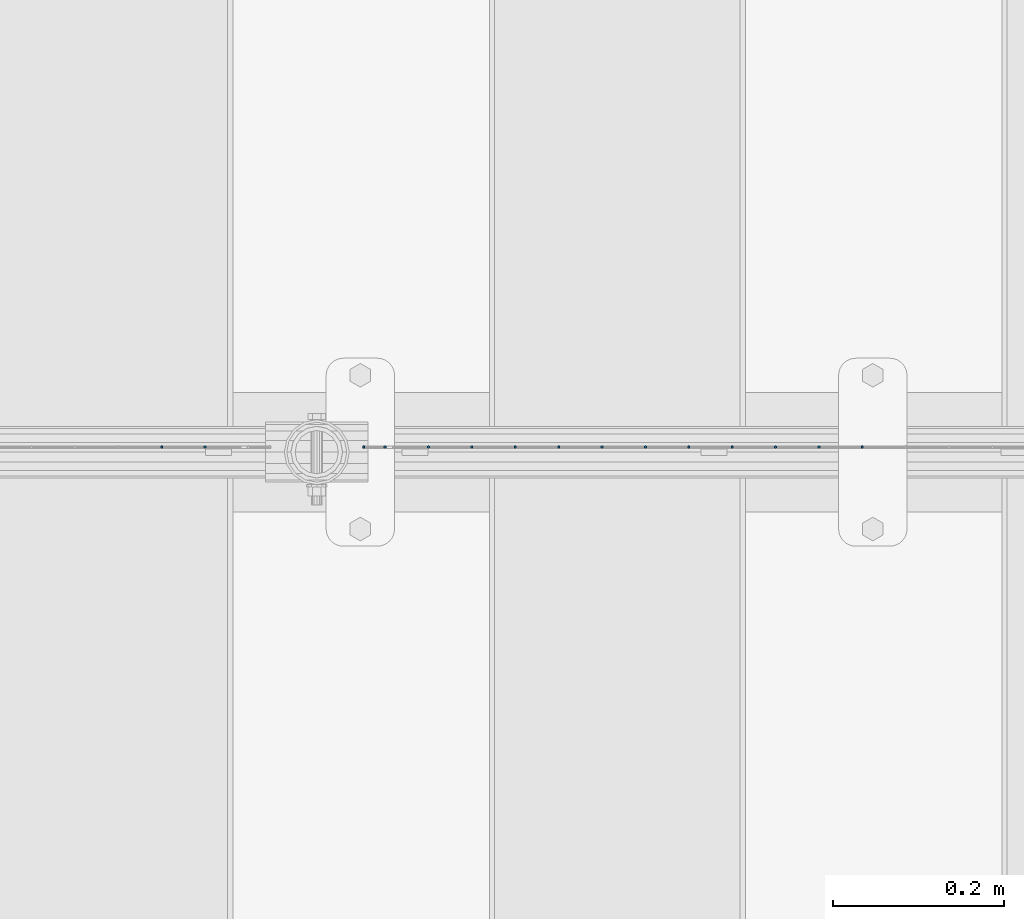
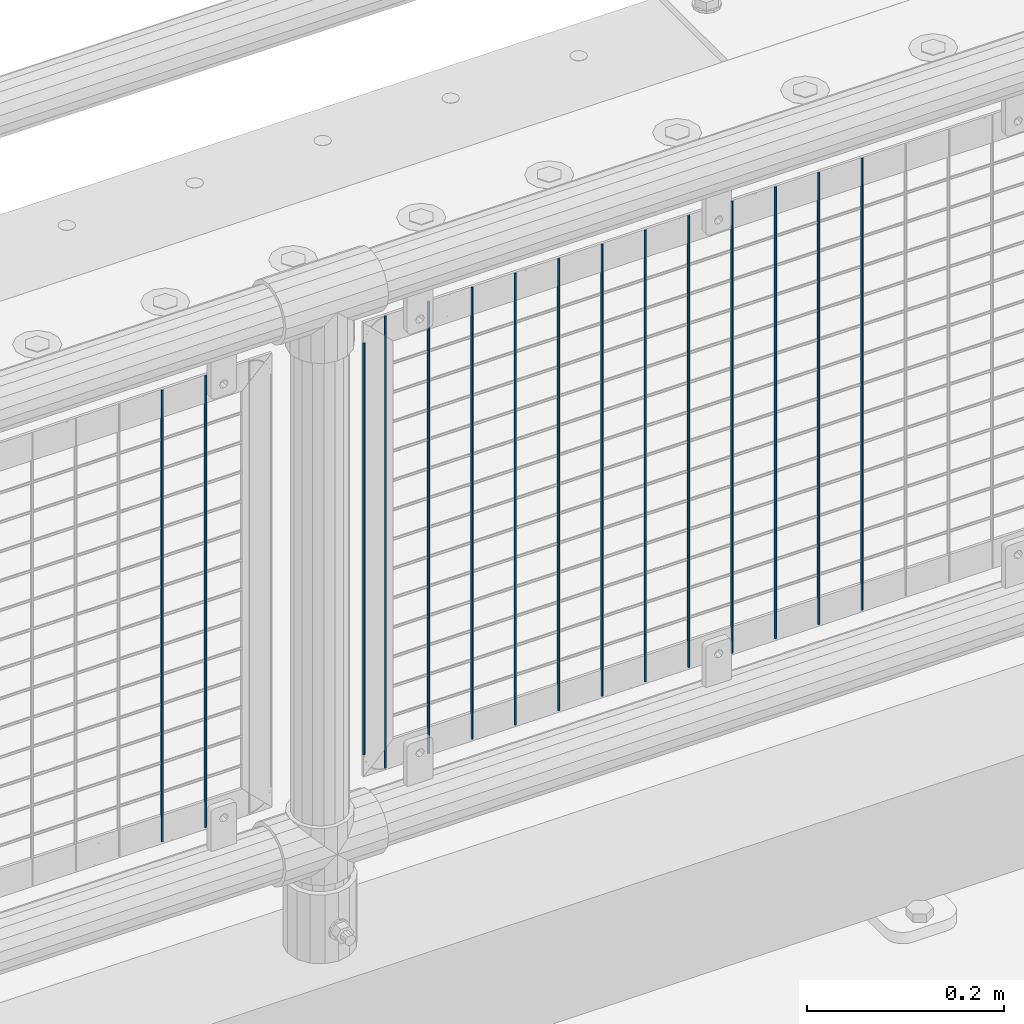
# One storey, part 101 of 270: 15 columns.
"""IFC2X3 building model written with IfcOpenShell, lengths in millimetres."""

from ifc_helpers import new_model, si_unit, frame, origin_with_axes, place, context, subcontext, project, spatial, faceted_brep, material, type_object, element, save


model = new_model("IFC2X3")

# Units and contexts
model_context = context("Model", 3, precision=1e-05, world=origin_with_axes())
body_context = subcontext(model_context, "Body", "Model", "MODEL_VIEW")
ifc_project = project(units=[si_unit("LENGTHUNIT", "METRE", prefix="MILLI"), si_unit("AREAUNIT", "SQUARE_METRE"), si_unit("VOLUMEUNIT", "CUBIC_METRE"), si_unit("MASSUNIT", "GRAM", prefix="KILO"), si_unit("TIMEUNIT", "SECOND"), si_unit("PLANEANGLEUNIT", "RADIAN"), si_unit("SOLIDANGLEUNIT", "STERADIAN"), si_unit("THERMODYNAMICTEMPERATUREUNIT", "DEGREE_CELSIUS"), si_unit("LUMINOUSINTENSITYUNIT", "LUMEN")], contexts=[model_context])

# Site, building, storey
site_placement = place(None, origin_with_axes())
site = spatial("IfcSite", under=ifc_project, at=site_placement, CompositionType="ELEMENT")
building_placement = place(site_placement, origin_with_axes())
building = spatial("IfcBuilding", under=site, at=building_placement, Name="Standard", CompositionType="ELEMENT")
storey_placement = place(building_placement, origin_with_axes())
storey = spatial("IfcBuildingStorey", under=building, at=storey_placement, Name="Undefined", CompositionType="ELEMENT", Elevation=0.0)

# Columns
ifc_material = material(Name="Misc_Undefined")
column_type = type_object("IfcColumnType", Name="D3", PredefinedType="NOTDEFINED")
for number, where, z_axis, x_axis in (
    (1, (15956.723, -16329.5, 353.02), (-1.0, 0.0, 0.0), (0.0, 0.0, 1.0)),
    (2, (15905.93, -16329.5, 353.02), (-1.0, 0.0, 0.0), (0.0, 0.0, 1.0)),
    (3, (15855.137, -16329.5, 353.02), (-1.0, 0.0, 0.0), (0.0, 0.0, 1.0)),
    (4, (15804.344, -16329.5, 353.02), (-1.0, 0.0, 0.0), (0.0, 0.0, 1.0)),
    (5, (15753.551, -16329.5, 353.02), (-1.0, 0.0, 0.0), (0.0, 0.0, 1.0)),
    (6, (15702.758, -16329.5, 353.02), (-1.0, 0.0, 0.0), (0.0, 0.0, 1.0)),
    (7, (15651.965, -16329.5, 353.02), (-1.0, 0.0, 0.0), (0.0, 0.0, 1.0)),
    (8, (15601.172, -16329.5, 353.02), (-1.0, 0.0, 0.0), (0.0, 0.0, 1.0)),
    (9, (15550.379, -16329.5, 353.02), (-1.0, 0.0, 0.0), (0.0, 0.0, 1.0)),
    (10, (15499.586, -16329.5, 353.02), (-1.0, 0.0, 0.0), (0.0, 0.0, 1.0)),
    (11, (15448.793, -16329.5, 353.02), (-1.0, 0.0, 0.0), (0.0, 0.0, 1.0)),
):
    element("IfcColumn", number, at=place(storey_placement, frame(where, z_axis=z_axis, x_axis=x_axis)), inside=storey, type_object=column_type, material=ifc_material, ObjectType="D3", context=body_context, shape_type="Brep", body=[
        faceted_brep([(0.0, -1.5, 0.0), (0.0, -0.75, -1.29903810567669), (560.0, -0.75, -1.29903810567703), (560.0, -1.5, 0.0), (0.0, 0.75, -1.29903810567669), (560.0, 0.75, -1.29903810567703), (0.0, 1.5, 0.0), (560.0, 1.5, 0.0), (0.0, 0.75, 1.29903810567669), (560.0, 0.75, 1.29903810567703), (0.0, -0.75, 1.29903810567669), (560.0, -0.75, 1.29903810567703)], [[[0, 1, 2, 3]], [[1, 4, 5, 2]], [[4, 6, 7, 5]], [[6, 8, 9, 7]], [[8, 10, 11, 9]], [[10, 0, 3, 11]], [[5, 7, 9, 11, 3, 2]], [[10, 8, 6, 4, 1, 0]]]),
    ])
column_placement = place(storey_placement, frame((15373.0, -16329.5, 378.02), z_axis=(-1.0, 0.0, 0.0), x_axis=(0.0, 0.0, 1.0)))
element("IfcColumn", 12, at=column_placement, inside=storey, type_object=column_type, material=ifc_material, ObjectType="D3", context=body_context, shape_type="Brep", body=[
    faceted_brep([(0.0, -1.5, 0.0), (0.0, -0.75, -1.29903810567669), (510.0, -0.75, -1.29903810567703), (510.0, -1.5, 0.0), (0.0, 0.75, -1.29903810567669), (510.0, 0.75, -1.29903810567703), (0.0, 1.5, 0.0), (510.0, 1.5, 0.0), (0.0, 0.75, 1.29903810567669), (510.0, 0.75, 1.29903810567703), (0.0, -0.75, 1.29903810567669), (510.0, -0.75, 1.29903810567703)], [[[0, 1, 2, 3]], [[1, 4, 5, 2]], [[4, 6, 7, 5]], [[6, 8, 9, 7]], [[8, 10, 11, 9]], [[10, 0, 3, 11]], [[5, 7, 9, 11, 3, 2]], [[10, 8, 6, 4, 1, 0]]]),
])
for number, where, z_axis, x_axis in (
    (13, (15398.0, -16329.5, 353.02), (-1.0, 0.0, 0.0), (0.0, 0.0, 1.0)),
    (14, (15187.204, -16329.5, 353.02), (-1.0, 0.0, 0.0), (0.0, 0.0, 1.0)),
    (15, (15136.411, -16329.5, 353.02), (-1.0, 0.0, 0.0), (0.0, 0.0, 1.0)),
):
    element("IfcColumn", number, at=place(storey_placement, frame(where, z_axis=z_axis, x_axis=x_axis)), inside=storey, type_object=column_type, material=ifc_material, ObjectType="D3", context=body_context, shape_type="Brep", body=[
        faceted_brep([(0.0, -1.5, 0.0), (0.0, -0.75, -1.29903810567669), (560.0, -0.75, -1.29903810567703), (560.0, -1.5, 0.0), (0.0, 0.75, -1.29903810567669), (560.0, 0.75, -1.29903810567703), (0.0, 1.5, 0.0), (560.0, 1.5, 0.0), (0.0, 0.75, 1.29903810567669), (560.0, 0.75, 1.29903810567703), (0.0, -0.75, 1.29903810567669), (560.0, -0.75, 1.29903810567703)], [[[0, 1, 2, 3]], [[1, 4, 5, 2]], [[4, 6, 7, 5]], [[6, 8, 9, 7]], [[8, 10, 11, 9]], [[10, 0, 3, 11]], [[5, 7, 9, 11, 3, 2]], [[10, 8, 6, 4, 1, 0]]]),
    ])

save(model, "model.ifc")
